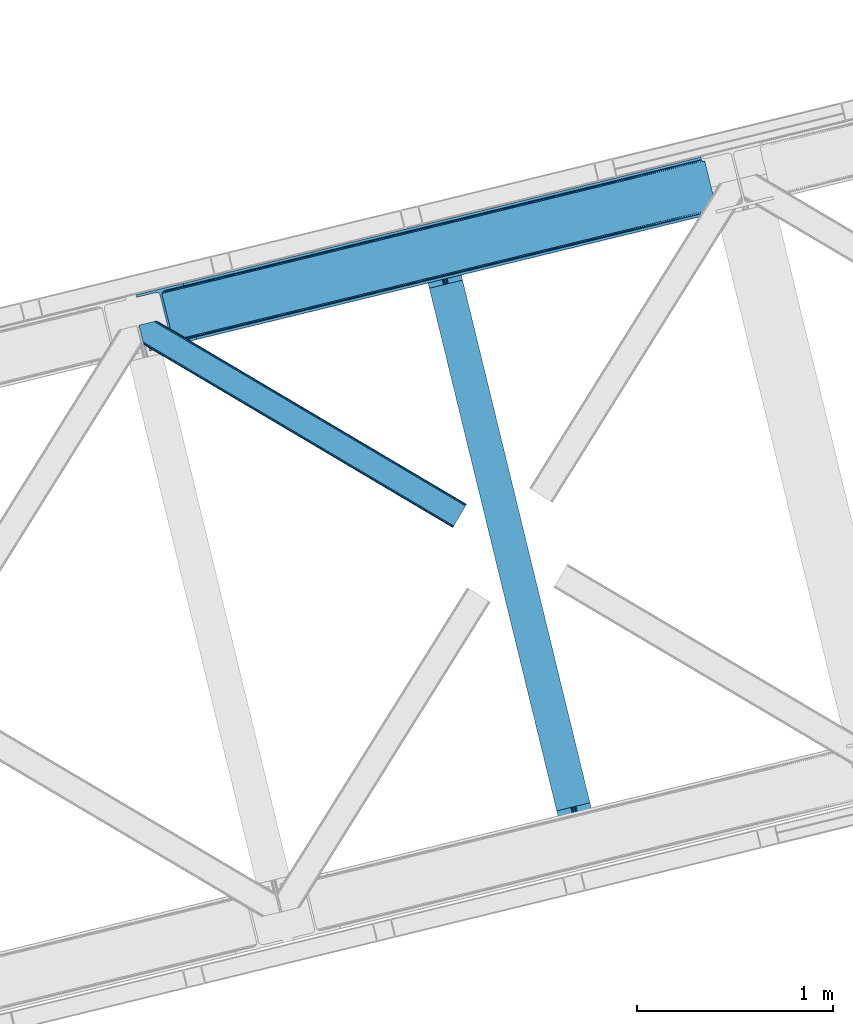
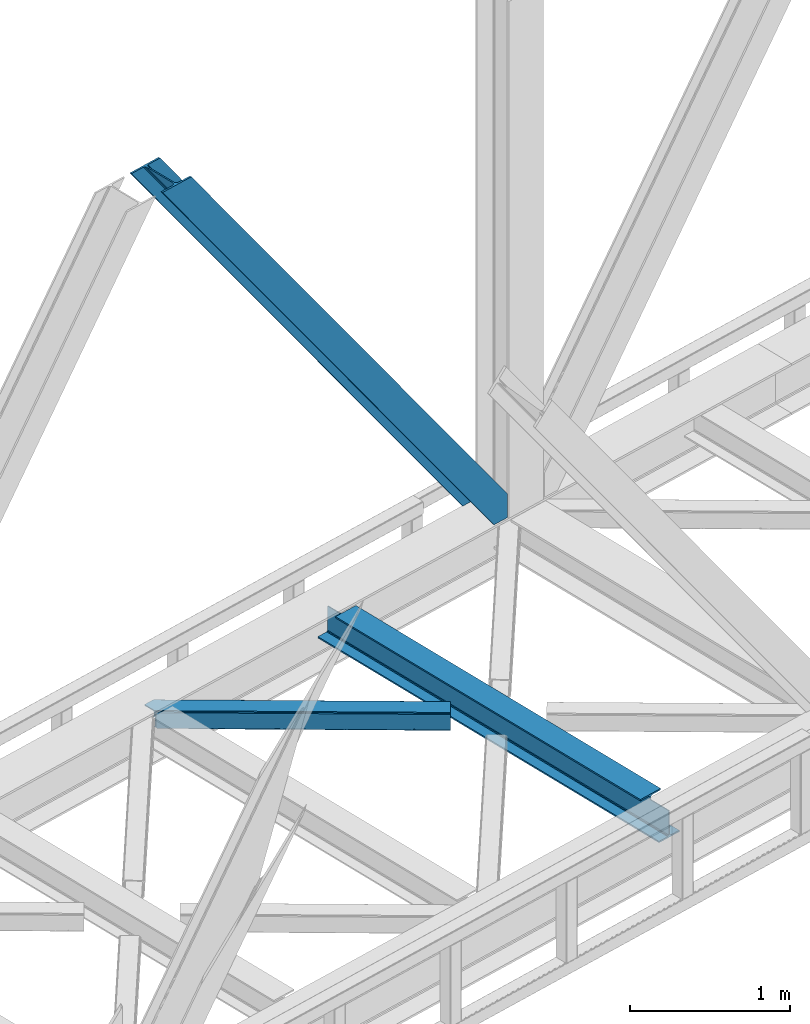
# One storey, part 60 of 93: 2 members, 1 beam.
"""IFC4 building model written with IfcOpenShell, lengths in millimetres."""

from ifc_helpers import new_model, entity, si_unit, converted_unit, derived_unit, direction, frame, origin, place, context, subcontext, project, spatial, triangles, polygons, material, type_object, element, save


model = new_model("IFC4")

# Units and contexts
model_context = context("Model", 3, precision=0.01, world=origin(), true_north=direction((6.12303176911189e-17, 1.0)))
plan_context = context("Plan", 3, precision=0.01, world=origin(), true_north=direction((6.12303176911189e-17, 1.0)))
body_context = subcontext(model_context, "Body", "Model", "MODEL_VIEW")
ifc_project = project(units=[si_unit("LENGTHUNIT", "METRE", prefix="MILLI"), si_unit("AREAUNIT", "SQUARE_METRE"), si_unit("VOLUMEUNIT", "CUBIC_METRE"), converted_unit("PLANEANGLEUNIT", "DEGREE", entity("IfcRatioMeasure", 0.0174532925199433), si_unit("PLANEANGLEUNIT", "RADIAN"), dimensions=[0, 0, 0, 0, 0, 0, 0]), si_unit("MASSUNIT", "GRAM", prefix="KILO"), derived_unit("MASSDENSITYUNIT", [(si_unit("MASSUNIT", "GRAM", prefix="KILO"), 1), (si_unit("LENGTHUNIT", "METRE"), -3)]), derived_unit("MOMENTOFINERTIAUNIT", [(si_unit("LENGTHUNIT", "METRE"), 4)]), si_unit("TIMEUNIT", "SECOND"), si_unit("FREQUENCYUNIT", "HERTZ"), si_unit("THERMODYNAMICTEMPERATUREUNIT", "DEGREE_CELSIUS"), derived_unit("THERMALTRANSMITTANCEUNIT", [(si_unit("MASSUNIT", "GRAM", prefix="KILO"), 1), (si_unit("THERMODYNAMICTEMPERATUREUNIT", "KELVIN"), -1), (si_unit("TIMEUNIT", "SECOND"), -3)]), derived_unit("VOLUMETRICFLOWRATEUNIT", [(si_unit("LENGTHUNIT", "METRE"), 3), (si_unit("TIMEUNIT", "SECOND"), -1)]), derived_unit("MASSFLOWRATEUNIT", [(si_unit("MASSUNIT", "GRAM", prefix="KILO"), 1), (si_unit("TIMEUNIT", "SECOND"), -1)]), derived_unit("ROTATIONALFREQUENCYUNIT", [(si_unit("TIMEUNIT", "SECOND"), -1)]), si_unit("ELECTRICCURRENTUNIT", "AMPERE"), si_unit("ELECTRICVOLTAGEUNIT", "VOLT"), si_unit("POWERUNIT", "WATT"), si_unit("FORCEUNIT", "NEWTON", prefix="KILO"), si_unit("ILLUMINANCEUNIT", "LUX"), si_unit("LUMINOUSFLUXUNIT", "LUMEN"), si_unit("LUMINOUSINTENSITYUNIT", "CANDELA"), derived_unit("USERDEFINED", [(si_unit("MASSUNIT", "GRAM", prefix="KILO"), -1), (si_unit("LENGTHUNIT", "METRE"), -2), (si_unit("TIMEUNIT", "SECOND"), 3), (si_unit("LUMINOUSFLUXUNIT", "LUMEN"), 1)]), derived_unit("LINEARVELOCITYUNIT", [(si_unit("LENGTHUNIT", "METRE"), 1), (si_unit("TIMEUNIT", "SECOND"), -1)]), si_unit("PRESSUREUNIT", "PASCAL"), derived_unit("USERDEFINED", [(si_unit("LENGTHUNIT", "METRE"), -2), (si_unit("MASSUNIT", "GRAM", prefix="KILO"), 1), (si_unit("TIMEUNIT", "SECOND"), -2)]), derived_unit("LINEARFORCEUNIT", [(si_unit("MASSUNIT", "GRAM", prefix="KILO"), 1), (si_unit("LENGTHUNIT", "METRE"), 1), (si_unit("TIMEUNIT", "SECOND"), -2), (si_unit("LENGTHUNIT", "METRE"), -1)]), derived_unit("PLANARFORCEUNIT", [(si_unit("MASSUNIT", "GRAM", prefix="KILO"), 1), (si_unit("LENGTHUNIT", "METRE"), 1), (si_unit("TIMEUNIT", "SECOND"), -2), (si_unit("LENGTHUNIT", "METRE"), -2)])], contexts=[model_context, plan_context])

# Site, building, storey
site_placement = place(None, origin())
site = spatial("IfcSite", under=ifc_project, at=site_placement, CompositionType="ELEMENT")
building_placement = place(site_placement, origin())
building = spatial("IfcBuilding", under=site, at=building_placement, CompositionType="ELEMENT")
storey_placement = place(building_placement, frame((0.0, 0.0, 15900.0)))
storey = spatial("IfcBuildingStorey", under=building, at=storey_placement, CompositionType="ELEMENT", Elevation=15900.0)

# Beam
ifc_material = material(Name="Metal painted (White)")
beam_type = type_object("IfcBeamType", PredefinedType="BEAM")
beam_placement = place(storey_placement, frame((-25639.1508905886, 11536.3709576732, 3441.0)))
element("IfcBeam", 1, at=beam_placement, inside=storey, type_object=beam_type, material=ifc_material, ObjectType="Steel Beam", PredefinedType="BEAM", context=body_context, shape_type="Tessellation", body=[
    polygons([(898.85391135252, 41.4445662733125, 11.000000000004), (898.85391135252, 41.4445662733103, 2.16573425859679e-12), (170.021610174757, 3031.3960252037, 2.16573425859679e-12), (170.021610174757, 3031.3960252037, 11.000000000004), (832.788371398898, 25.3403919499699, 11.000000000004), (103.956070221131, 3015.29185088035, 11.000000000004), (826.839621377601, 23.8903211957417, 12.217927479826), (98.007320199834, 3013.84178012613, 12.217927479826), (821.796514621497, 22.6610105689216, 15.6862915010192), (92.964213443734, 3012.61246949931, 15.6862915010192), (818.426818418321, 21.8396114687162, 20.8770650821657), (89.5945172405625, 3011.7910703991, 20.8770650821657), (817.243538468639, 21.5511744621227, 27.0000000000047), (88.4112372908766, 3011.50263339251, 27.0000000000047), (81.6103728838801, 3009.84485074157, 27.0000000000047), (81.6103728838801, 3009.84485074157, 203.000000000006), (88.4112372908766, 3011.50263339251, 203.000000000006), (0.0, 2989.95145893039, 2.16573425859679e-12), (0.0, 2989.95145893039, 10.9999999999997), (66.0655399536172, 3006.05563325373, 11.000000000004), (72.014289974914, 3007.50570400796, 12.2179274798217), (77.057396731014, 3008.73501463478, 15.6862915010192), (80.4270929341986, 3009.55641373499, 20.8770650821657), (817.243538468639, 21.5511744621227, 203.000000000006), (810.442674061647, 19.8933918111897, 203.000000000006), (810.442674061647, 19.8933918111897, 27.0000000000047), (809.259394111961, 19.6049548046006, 20.8770650821657), (805.889697908777, 18.7835557043887, 15.6862915010192), (800.846591152677, 17.5542450775707, 12.2179274798217), (794.89784113138, 16.1041743233447, 11.000000000004), (728.832301177763, 2.16573425859679e-12, 10.9999999999997), (728.832301177763, 2.16573425859679e-12, 2.16573425859679e-12), (777.543778045845, 184.415062601696, 203.069791966819), (125.888966506592, 2857.75452019163, 203.000000000006), (126.111847295742, 2856.8401777572, 203.617301946336), (126.124761540265, 2856.78719778431, 217.000003693143), (777.398574796912, 185.010597404074, 217.000003676718), (777.39944540481, 185.007025963197, 204.00000679514), (770.833476881408, 182.385463974447, 203.006342981529), (770.610629219861, 183.299815969778, 203.617301946336), (770.597714975342, 183.352795942671, 217.000003693143), (119.323901718691, 2855.1293963229, 217.000003676718), (119.323031110798, 2855.13296776378, 204.00000679514), (119.178731521747, 2855.72494066435, 203.076120467494), (119.088102099599, 2856.09673754069, 203.000000000006), (778.582059520948, 185.298194377516, 223.122939328039), (781.951055929627, 186.122464201395, 228.313710402595), (786.993691333638, 187.353708426701, 231.782072735464), (792.942270204354, 188.804481281383, 232.999999602236), (859.007721069869, 204.909021065317, 232.999999283132), (859.006247733431, 204.91506504219, 243.999994005812), (688.984866829519, 163.4695582453, 243.999994827032), (688.986340165957, 163.463514268429, 233.000000104353), (755.05179103148, 179.568054052363, 232.999999785253), (761.00069615981, 181.017488520586, 231.782072861012), (766.044260666937, 182.244921343719, 228.313710479427), (769.414647576681, 183.06348700115, 223.12293937232), (118.140416994651, 2854.84179934946, 223.122939328039), (114.771420585976, 2854.01752952557, 228.313710402599), (109.728785181961, 2852.78628530027, 231.782072735464), (103.780206311245, 2851.33551244559, 232.999999602236), (37.7147554457299, 2835.23097266165, 232.999999283128), (37.7162287821674, 2835.22492868478, 243.999994005812), (207.73760968608, 2876.67043548167, 243.999994827032), (207.736136349642, 2876.67647945855, 233.000000104357), (141.670685484119, 2860.57193967461, 232.999999785253), (135.721780355789, 2859.12250520638, 231.782072861012), (130.678215848667, 2857.89507238325, 228.313710479427), (127.307828938918, 2857.07650672582, 223.12293937232)], [[[1, 2, 3, 4]], [[5, 1, 4, 6]], [[7, 5, 6, 8]], [[9, 7, 8, 10]], [[11, 9, 10, 12]], [[13, 11, 12, 14]], [[15, 16, 17, 14, 12, 10, 8, 6, 4, 3, 18, 19, 20, 21, 22, 23]], [[13, 24, 25, 26, 27, 28, 29, 30, 31, 32, 2, 1, 5, 7, 9, 11]], [[2, 32, 18, 3]], [[32, 31, 19, 18]], [[31, 30, 20, 19]], [[27, 26, 15, 23]], [[28, 27, 23, 22]], [[29, 28, 22, 21]], [[30, 29, 21, 20]], [[33, 24, 13, 14, 17, 34, 35, 36, 37, 38]], [[25, 39, 40, 41, 42, 43, 44, 16, 15, 26]], [[39, 25, 24, 33]], [[45, 34, 17, 16]], [[41, 40, 38, 37, 46, 47, 48, 49, 50, 51, 52, 53, 54, 55, 56, 57]], [[42, 58, 59, 60, 61, 62, 63, 64, 65, 66, 67, 68, 69, 36, 35, 43]], [[46, 37, 36, 69]], [[47, 46, 69, 68]], [[48, 47, 68, 67]], [[49, 48, 67, 66]], [[50, 49, 66, 65]], [[51, 50, 65, 64]], [[52, 51, 64, 63]], [[53, 52, 63, 62]], [[54, 53, 62, 61]], [[55, 54, 61, 60]], [[56, 55, 60, 59]], [[57, 56, 59, 58]], [[41, 57, 58, 42]]], closed=False),
])

# Members
member_type_1 = type_object("IfcMemberType", PredefinedType="BRACE")
member_1_placement = place(storey_placement, frame((-27100.5295349121, 14051.5178924561, 3694.99929199219)))
element("IfcMember", 2, at=member_1_placement, inside=storey, type_object=member_type_1, ObjectType="Steel Vertical Brace", PredefinedType="BRACE", context=body_context, shape_type="Tessellation", body=[
    triangles([(2966.89332275391, 730.999566650391, 0.80925292968459), (2967.55142211914, 730.015905761718, 1.10690917968532), (2966.08174438477, 729.657788085939, 0.0), (2964.18651123047, 737.429406738282, 0.0), (2962.43545532227, 728.768307495118, 8.31577148437282), (2962.43545532227, 728.768307495118, 0.0), (2505.85634765625, 612.606793212892, 658.855133056641), (2511.3606628418, 609.931375122071, 662.301434326171), (2954.04294433594, 717.839904785156, 38.6743835449197), (2954.17084350586, 719.764205932617, 32.1678039550752), (2501.41243286133, 617.533236694337, 656.552947998047), (2958.54266967774, 726.957952880859, 14.8293273925774), (2955.07311401367, 722.241961669923, 26.1867736816384), (2955.64052124024, 723.796517944336, 22.4381652832017), (655.166986083987, 156.054428100586, 3289.34108276367), (649.437103271484, 156.068380737304, 3285.27854003906), (213.879968261721, 48.4865753173835, 3911.00081176758), (205.268865966798, 47.7982452392571, 3911.00081176758), (643.935113525393, 158.743798828125, 3281.83223876953), (197.318188476565, 49.8760253906257, 3911.00081176758), (639.491198730469, 163.67024230957, 3279.53005371094), (191.241815185549, 54.4048187255867, 3911.00081176758), (636.784387207033, 170.100082397461, 3278.7231262207), (187.960620117188, 60.6951324462898, 3911.00081176758), (2954.16154174805, 716.45859375, 50.6410949707024), (2517.08822021485, 609.918585205078, 666.36397705078), (2051.60965576172, 496.452255249023, 1322.10767211914), (2045.87977294922, 496.466207885742, 1318.04512939453), (1586.12876586914, 382.987088012695, 1977.85369262695), (1580.39888305664, 382.999877929688, 1973.78882446289), (1120.64787597656, 269.52075805664, 2633.59738769531), (1114.91799316406, 269.534710693359, 2629.53251953125), (2040.37545776367, 499.140463256836, 1314.598828125), (1574.89689331055, 385.675296020509, 1970.34484863281), (1109.41600341797, 272.208966064452, 2626.08854370117), (2035.93154296875, 504.068069458008, 1312.29896850586), (1570.45065307617, 390.601739501953, 1968.04266357422), (1104.9697631836, 277.136572265625, 2623.78635864258), (2498.70562133789, 623.964239501953, 655.74602050781), (2033.22473144531, 510.497909545898, 1311.48971557617), (1567.74384155274, 397.03274230957, 1967.23341064453), (1102.26527709961, 283.566412353515, 2622.97710571289), (2909.00615844727, 963.801635742188, 0.0), (2443.52526855469, 850.335305786133, 655.74602050781), (1978.04437866211, 736.870138549804, 1311.48971557617), (1512.56348876953, 623.40380859375, 1967.23341064453), (1047.08259887695, 509.937478637696, 2622.97710571289), (581.604034423828, 396.472311401367, 3278.7231262207), (132.780267333987, 287.067361450196, 3911.00081176758), (307.43239746094, 71.2909973144524, 3911.00081176758), (2954.16154174805, 716.45859375, 182.433050537107), (2954.35222778321, 715.476095581054, 0.0), (2954.17084350586, 719.764205932617, 0.0), (2954.35222778321, 715.476095581054, 182.495837402341), (2955.64052124024, 723.796517944336, 0.0), (2958.54266967774, 726.957952880859, 0.0), (2957.19624023438, 703.817504882813, 182.495837402341), (310.511279296876, 58.6603729248054, 3911.00081176758), (2957.19624023438, 703.817504882813, 0.0), (2846.09139404297, 676.735437011719, 0.0), (69.8655029296897, 0.0, 3911.00081176758), (2843.01251220703, 689.364898681641, 0.0), (66.78662109375, 12.6306243896488, 3911.00081176758), (160.336724853518, 35.4350463867195, 3911.00081176758), (2936.56494140625, 712.169320678711, 0.0), (2953.95922851563, 734.936535644532, 0.0), (2953.940625, 727.842782592774, 0.0), (177.733337402344, 58.2022613525387, 3911.00081176758), (177.714733886722, 51.1073455810547, 3911.00081176758), (2950.62919921875, 721.024594116212, 0.0), (174.403308105469, 44.2903198242184, 3911.00081176758), (2944.52724609375, 715.520278930664, 0.0), (168.301354980471, 38.7860046386722, 3911.00081176758), (2898.77887573242, 961.307601928711, 0.0), (122.552984619142, 284.573327636719, 3911.00081176758), (2872.85720214844, 973.517321777344, 0.0), (2881.46830444336, 974.205651855469, 0.0), (105.244738769532, 297.471377563477, 3911.00081176758), (96.6289855957039, 296.781884765625, 3911.00081176758), (2889.4189819336, 972.127871704102, 0.0), (113.193090820314, 295.393597412109, 3911.00081176758), (2895.49768066406, 967.599078369141, 0.0), (119.271789550781, 290.864804077148, 3911.00081176758), (3.07888183593968, 273.978625488282, 3911.00081176758), (2779.30477294922, 950.712899780274, 0.0), (2776.22589111328, 963.342361450195, 0.0), (0.0, 286.608087158203, 3911.00081176758), (142.212249755859, 306.482455444337, 3911.00081176758), (150.174554443362, 309.834576416015, 3911.00081176758), (136.110296630861, 300.979302978516, 3911.00081176758), (132.798870849612, 294.161114501952, 3911.00081176758), (240.648101806641, 345.268460083007, 3911.00081176758), (243.72698364258, 332.638998413086, 3911.00081176758), (2887.33073730469, 990.425592041016, 182.495837402341), (2887.33073730469, 990.425592041016, 0.0), (2890.45612792969, 977.806594848633, 182.433050537107), (2890.17242431641, 978.767001342774, 182.495837402341), (1522.42102661133, 644.333926391602, 1977.85369262695), (591.461572265627, 417.402429199219, 3289.34108276367), (1056.9424621582, 530.867596435546, 2633.59738769531), (1987.90191650391, 757.800256347657, 1322.10767211914), (2453.38280639649, 871.265423583985, 666.36397705078), (2890.45612792969, 977.806594848633, 50.6410949707024), (2890.17242431641, 978.767001342774, 0.0), (2890.986328125, 976.525277709961, 38.6743835449197), (2892.14672241211, 974.999789428712, 33.1630920410134), (2891.98394165039, 974.87537841797, 0.0), (2893.56524047852, 973.138275146484, 26.4425720214822), (2895.14421386719, 971.973229980469, 22.4381652832017), (2903.46463623047, 970.684936523438, 8.31577148437282), (2903.46463623047, 970.684936523438, 0.0), (2899.17652587891, 970.50122680664, 0.0), (2899.17652587891, 970.50122680664, 14.8293273925774), (2895.14421386719, 971.973229980469, 0.0), (2907.11092529297, 971.573254394532, 0.0), (2444.64845581055, 863.710070800782, 658.855133056641), (2442.96948852539, 857.29069519043, 656.552947998047), (2908.45037841797, 970.755862426759, 0.80925292968459), (2908.5829284668, 971.932534790039, 1.10690917968532), (581.048254394533, 403.426538085938, 3279.53005371094), (582.724896240237, 409.847076416016, 3281.83223876953), (586.380487060549, 414.753753662109, 3285.27854003906), (2448.30404663086, 868.616748046876, 662.301434326171), (1977.48859863282, 743.824365234375, 1312.29896850586), (1512.00770874024, 630.358035278321, 1968.04266357422), (1046.52681884766, 516.892868041992, 2623.78635864258), (1979.16756591797, 750.243740844728, 1314.598828125), (1513.68667602539, 636.778573608399, 1970.34484863281), (1048.20578613281, 523.312243652344, 2626.08854370117), (1982.82315673828, 755.151580810547, 1318.04512939453), (1517.34226684571, 641.685250854493, 1973.78882446289), (1051.86137695313, 528.218920898438, 2629.53251953125)], [[1, 2, 3], [3, 4, 1], [2, 5, 6], [6, 3, 2], [7, 8, 9], [9, 10, 7], [11, 12, 5], [5, 1, 11], [11, 7, 13], [13, 14, 11], [14, 12, 11], [15, 16, 17], [18, 17, 16], [16, 19, 18], [20, 18, 19], [19, 21, 20], [22, 20, 21], [21, 23, 22], [24, 22, 23], [5, 2, 1], [10, 13, 7], [25, 9, 8], [8, 26, 25], [26, 8, 27], [28, 27, 8], [27, 28, 29], [30, 29, 28], [29, 30, 31], [32, 31, 30], [31, 32, 15], [16, 15, 32], [8, 7, 33], [33, 28, 8], [28, 33, 34], [34, 30, 28], [30, 34, 35], [35, 32, 30], [32, 35, 16], [19, 16, 35], [7, 11, 36], [36, 33, 7], [33, 36, 37], [37, 34, 33], [34, 37, 38], [38, 35, 34], [35, 38, 21], [21, 19, 35], [1, 4, 11], [39, 11, 4], [11, 39, 36], [40, 36, 39], [36, 40, 37], [41, 37, 40], [37, 41, 42], [42, 38, 37], [38, 42, 23], [23, 21, 38], [4, 43, 44], [45, 39, 44], [41, 40, 45], [41, 45, 46], [44, 39, 4], [45, 40, 39], [42, 41, 46], [46, 47, 42], [47, 48, 23], [49, 24, 48], [47, 23, 42], [48, 24, 23], [50, 51, 29], [29, 31, 50], [31, 15, 50], [17, 50, 15], [27, 29, 51], [51, 25, 26], [26, 27, 51], [52, 9, 25], [52, 53, 10], [10, 9, 52], [25, 51, 54], [54, 52, 25], [14, 53, 55], [53, 14, 13], [10, 53, 13], [56, 12, 55], [14, 55, 12], [6, 5, 56], [12, 56, 5], [57, 54, 58], [54, 51, 50], [50, 58, 54], [57, 59, 52], [52, 54, 57], [58, 60, 57], [58, 61, 60], [60, 59, 57], [62, 60, 63], [61, 63, 60], [63, 64, 62], [65, 62, 64], [66, 67, 68], [69, 68, 67], [67, 70, 69], [71, 69, 70], [70, 72, 71], [73, 71, 72], [72, 65, 73], [64, 73, 65], [74, 66, 75], [68, 75, 66], [76, 77, 78], [78, 79, 76], [77, 80, 81], [81, 78, 77], [80, 82, 83], [83, 81, 80], [82, 74, 75], [75, 83, 82], [79, 84, 85], [85, 76, 79], [86, 85, 87], [84, 87, 85], [75, 68, 49], [71, 73, 18], [64, 61, 17], [63, 61, 64], [73, 64, 17], [68, 69, 22], [69, 71, 20], [81, 88, 78], [87, 79, 89], [79, 78, 89], [87, 84, 79], [81, 83, 90], [83, 75, 91], [49, 68, 24], [17, 18, 73], [22, 69, 20], [18, 20, 71], [22, 24, 68], [58, 17, 61], [58, 50, 17], [89, 78, 88], [90, 83, 91], [49, 91, 75], [90, 88, 81], [89, 92, 87], [92, 89, 93], [92, 86, 87], [86, 92, 94], [95, 86, 94], [96, 97, 93], [97, 94, 92], [92, 93, 97], [98, 96, 93], [93, 99, 100], [99, 93, 89], [100, 98, 93], [96, 98, 101], [101, 102, 96], [103, 96, 102], [97, 104, 94], [95, 94, 104], [104, 105, 106], [96, 103, 97], [104, 97, 103], [103, 105, 104], [107, 108, 109], [107, 106, 108], [110, 111, 112], [112, 113, 110], [113, 112, 114], [114, 109, 113], [109, 114, 107], [106, 107, 104], [53, 70, 55], [76, 86, 95], [85, 86, 76], [77, 76, 95], [104, 80, 77], [77, 95, 104], [104, 107, 80], [60, 65, 59], [52, 72, 70], [65, 72, 59], [60, 62, 65], [70, 53, 52], [52, 59, 72], [43, 66, 74], [82, 112, 74], [80, 114, 82], [80, 107, 114], [82, 114, 112], [111, 43, 74], [112, 111, 74], [43, 111, 115], [4, 66, 43], [56, 66, 6], [55, 70, 67], [67, 66, 56], [56, 55, 67], [4, 6, 66], [3, 6, 4], [116, 113, 109], [117, 118, 113], [113, 116, 117], [109, 108, 116], [118, 119, 110], [110, 113, 118], [48, 120, 91], [91, 49, 48], [120, 121, 90], [90, 91, 120], [121, 122, 88], [88, 90, 121], [122, 99, 89], [89, 88, 122], [105, 103, 123], [102, 123, 103], [106, 116, 108], [116, 106, 105], [123, 116, 105], [43, 118, 117], [117, 44, 43], [44, 117, 124], [124, 45, 44], [45, 124, 125], [125, 46, 45], [46, 125, 47], [126, 47, 125], [47, 126, 48], [120, 48, 126], [117, 116, 124], [127, 124, 116], [124, 127, 125], [128, 125, 127], [125, 128, 126], [129, 126, 128], [126, 129, 120], [121, 120, 129], [116, 123, 127], [130, 127, 123], [127, 130, 128], [131, 128, 130], [128, 131, 129], [132, 129, 131], [129, 132, 122], [122, 121, 129], [123, 102, 101], [101, 130, 123], [130, 101, 98], [98, 131, 130], [131, 98, 100], [100, 132, 131], [132, 100, 99], [99, 122, 132], [110, 119, 111], [115, 111, 119], [119, 118, 115], [43, 115, 118]]),
])
member_type_2 = type_object("IfcMemberType", PredefinedType="BRACE")
member_2_placement = place(storey_placement, frame((-27085.4955688477, 13147.4358673096, 3510.00011901855)))
element("IfcMember", 3, at=member_2_placement, inside=storey, type_object=member_type_2, ObjectType="Steel Horizontal Brace", PredefinedType="BRACE", context=body_context, shape_type="Tessellation", body=[
    triangles([(1674.92102050781, 120.470553588868, 122.500662231447), (1674.92102050781, 120.470553588868, 17.5000946044929), (91.5037170410178, 1057.89356689453, 17.5000946044929), (91.5037170410178, 1057.89356689453, 122.500662231447), (1666.00528564453, 105.412170410156, 139.999594116212), (1669.41670532227, 111.174609375001, 138.667117309571), (76.4813781738303, 1054.23099975586, 138.667117309571), (67.1679931640647, 1051.96137084961, 139.999594116212), (1672.30955200196, 116.060357666016, 134.874325561526), (84.3762451171897, 1056.15530090332, 134.874325561526), (1674.2419921875, 119.324111938477, 129.197927856447), (89.6503417968779, 1057.4412689209, 129.197927856447), (18.7686218261733, 958.59497680664, 139.999594116212), (1612.51552734375, 15.0595458984371, 139.999594116212), (0.0, 1035.58795166016, 139.999594116212), (1603.59746704102, 0.0, 122.500662231447), (1604.27882080078, 1.14644165039135, 129.197927856447), (24.5612915039092, 934.827822875977, 122.500662231447), (24.1194580078154, 936.637014770507, 129.197927856447), (1606.21126098633, 4.41135864257922, 134.874325561526), (22.8637207031279, 941.789025878907, 134.874325561526), (1609.10178222656, 9.29594421386719, 138.667117309571), (20.9847656250022, 949.499020385743, 138.667117309571), (1603.59746704102, 0.0, 17.5000946044929), (24.5612915039092, 934.827822875977, 17.5000946044929), (1674.2419921875, 119.324111938477, 10.8028289794929), (89.5619750976584, 1057.42033996582, 10.8167816162131), (162.736578369142, 1014.02182617187, 10.5005218505867), (1672.30955200196, 116.060357666016, 5.12526855468968), (165.152709960938, 1008.33263854981, 5.12526855468968), (164.09696044922, 1012.66493225098, 9.50058288574292), (163.771398925783, 1012.99281921387, 9.74126586914281), (163.417932128908, 1013.34279785156, 10.0005523681648), (163.066790771485, 1013.69393920898, 10.2586761474631), (89.4712829589844, 1057.39708557129, 10.5005218505867), (1669.41670532227, 111.174609375001, 1.33247680664135), (167.031665039063, 1000.62264404297, 1.33247680664135), (1666.00528564453, 105.412170410156, 0.0), (169.250134277347, 991.52668762207, 0.0), (1612.51552734375, 15.0595458984371, 0.0), (204.010803222656, 848.92608947754, 0.0), (166.88748779297, 996.992633056641, 10.5005218505867), (72.035137939456, 1053.1473449707, 10.5005218505867), (168.582733154297, 994.261404418945, 9.50058288574292), (168.166479492189, 994.934619140626, 9.74591674804833), (167.736273193361, 995.627600097656, 10.0005523681648), (167.306066894533, 996.319418334961, 10.2540252685576), (1668.74465332031, 110.036306762695, 12.1260040283232), (1670.67476806641, 113.301223754883, 17.8035644531265), (79.9183776855498, 1055.06932067871, 17.8035644531265), (1665.85180664063, 105.151721191407, 8.3320495605476), (169.398962402345, 990.918585205078, 8.81690368652562), (74.1164062500029, 1053.65429077148, 12.4271484375022), (171.566271972657, 982.020291137696, 6.99957275390625), (1662.43806152344, 99.388119506837, 6.99957275390625), (1671.35612182617, 114.447665405274, 24.4996673583992), (81.7694274902351, 1055.52045593262, 24.4996673583992), (1671.35612182617, 114.447665405274, 115.501089477541), (81.7694274902351, 1055.52045593262, 115.501089477541), (74.641955566407, 1053.78335266113, 127.87475280762), (66.7494140625022, 1051.85905151367, 131.667544555665), (79.9183776855498, 1055.06932067871, 122.196029663086), (57.4360290527366, 1049.5882598877, 133.000021362306), (0.0, 1035.58795166016, 133.000021362306), (1670.67476806641, 113.301223754883, 122.196029663086), (1668.74465332031, 110.036306762695, 127.87475280762), (1665.85180664063, 105.151721191407, 131.667544555665), (1662.43806152344, 99.388119506837, 133.000021362306), (16.4501586914084, 968.101373291016, 133.000021362306), (1616.08042602539, 21.0824340820309, 133.000021362306), (1616.08042602539, 21.0824340820309, 6.99957275390625), (201.692340087891, 858.433648681641, 6.99957275390625), (1609.77615966797, 10.434246826173, 127.87475280762), (1612.66900634766, 15.3199951171882, 131.667544555665), (1607.16469116211, 6.02405090332104, 115.501089477541), (1607.84371948242, 7.1693298339851, 122.196029663086), (1609.10178222656, 9.29594421386719, 1.33247680664135), (1609.77615966797, 10.434246826173, 12.1260040283232), (1606.21126098633, 4.41135864257922, 5.12526855468968), (1612.66900634766, 15.3199951171882, 8.3320495605476), (1604.27882080078, 1.14644165039135, 10.8028289794929), (1607.16469116211, 6.02405090332104, 24.4996673583992), (1607.84371948242, 7.1693298339851, 17.8035644531265), (18.6686279296882, 959.006579589844, 131.667544555665), (20.547583007814, 951.295422363282, 127.87475280762), (21.8033203125015, 946.143411254883, 122.196029663086), (22.2451538085952, 944.334219360351, 115.501089477541), (22.2451538085952, 944.334219360351, 24.4996673583992), (21.7823913574248, 946.229452514648, 17.8163543701194), (21.7614624023445, 946.318981933595, 17.5000946044929), (203.861975097658, 849.534191894532, 8.81690368652562), (206.226947021485, 839.831295776368, 1.33247680664135), (204.675878906251, 846.191372680665, 9.50058288574292), (208.105902099611, 832.121301269532, 5.12526855468968), (209.161651611328, 827.789007568359, 9.50058288574292), (204.685180664063, 844.928659057618, 10.2075164794951), (204.324737548828, 844.906567382814, 10.3540191650391), (203.966619873048, 844.885638427735, 10.5005218505867), (27.014630126956, 947.468911743164, 12.1260040283232), (28.3494323730483, 948.857199096679, 10.5005218505867), (204.680529785157, 845.560015869141, 9.85404968261719), (32.1375732421875, 931.964044189453, 10.8179443359404), (209.136071777346, 827.584368896485, 9.88311767578125), (208.117529296876, 827.8564453125, 10.5005218505867), (208.803533935548, 827.672735595703, 10.0842681884787), (32.5003417968765, 931.828005981446, 10.5005218505867)], [[1, 2, 3], [3, 4, 1], [5, 6, 7], [7, 8, 5], [6, 9, 10], [10, 7, 6], [9, 11, 12], [12, 10, 9], [11, 1, 4], [4, 12, 11], [5, 13, 14], [13, 5, 8], [15, 13, 8], [16, 17, 18], [19, 18, 17], [17, 20, 19], [21, 19, 20], [20, 22, 21], [23, 21, 22], [22, 14, 23], [13, 23, 14], [24, 16, 18], [18, 25, 24], [26, 27, 3], [27, 26, 28], [26, 29, 30], [30, 31, 26], [26, 32, 33], [32, 26, 31], [26, 34, 28], [34, 26, 33], [28, 35, 27], [29, 36, 37], [37, 30, 29], [36, 38, 39], [39, 37, 36], [3, 2, 26], [38, 40, 41], [41, 39, 38], [28, 42, 35], [43, 35, 42], [31, 44, 45], [45, 32, 31], [32, 45, 46], [46, 33, 32], [33, 46, 47], [47, 34, 33], [34, 47, 42], [42, 28, 34], [48, 49, 50], [45, 51, 46], [45, 44, 51], [42, 47, 51], [47, 46, 51], [44, 52, 51], [48, 53, 42], [42, 51, 48], [53, 43, 42], [51, 52, 54], [54, 55, 51], [50, 53, 48], [49, 56, 57], [57, 50, 49], [56, 58, 57], [59, 57, 58], [60, 61, 7], [10, 60, 7], [10, 12, 62], [60, 10, 62], [62, 12, 4], [61, 8, 7], [15, 63, 64], [15, 8, 63], [61, 63, 8], [62, 4, 59], [57, 3, 50], [4, 57, 59], [3, 27, 50], [4, 3, 57], [35, 50, 27], [35, 53, 50], [35, 43, 53], [58, 65, 59], [62, 59, 65], [65, 66, 62], [60, 62, 66], [66, 67, 60], [61, 60, 67], [67, 68, 61], [63, 61, 68], [68, 69, 63], [68, 70, 69], [69, 64, 63], [71, 55, 72], [54, 72, 55], [11, 66, 65], [58, 2, 1], [11, 65, 1], [11, 9, 66], [65, 58, 1], [66, 9, 6], [68, 5, 14], [5, 67, 6], [67, 5, 68], [67, 66, 6], [26, 48, 29], [56, 2, 58], [2, 49, 26], [49, 2, 56], [26, 49, 48], [38, 55, 40], [36, 29, 48], [48, 51, 36], [51, 55, 38], [38, 36, 51], [73, 22, 20], [14, 70, 68], [14, 74, 70], [74, 14, 22], [73, 74, 22], [75, 16, 24], [17, 76, 73], [20, 17, 73], [76, 17, 16], [75, 76, 16], [77, 78, 79], [40, 55, 71], [71, 80, 40], [80, 78, 77], [77, 40, 80], [81, 79, 78], [24, 82, 75], [83, 24, 81], [24, 83, 82], [83, 81, 78], [70, 74, 84], [84, 69, 70], [74, 73, 85], [85, 84, 74], [73, 76, 86], [86, 85, 73], [76, 75, 87], [87, 86, 76], [75, 82, 88], [88, 87, 75], [86, 87, 18], [18, 19, 86], [21, 86, 19], [86, 21, 85], [18, 88, 25], [89, 90, 25], [25, 88, 89], [87, 88, 18], [84, 23, 13], [15, 69, 13], [64, 69, 15], [84, 85, 23], [23, 85, 21], [69, 84, 13], [44, 30, 37], [39, 44, 37], [54, 52, 39], [54, 39, 72], [30, 44, 31], [39, 52, 44], [72, 41, 91], [41, 92, 93], [41, 72, 39], [94, 93, 92], [41, 93, 91], [94, 95, 93], [83, 89, 88], [71, 72, 91], [78, 96, 97], [97, 98, 78], [98, 99, 78], [98, 100, 99], [80, 91, 93], [93, 78, 80], [78, 93, 101], [101, 96, 78], [83, 78, 99], [99, 90, 83], [90, 89, 83], [91, 80, 71], [88, 82, 83], [24, 25, 102], [79, 103, 95], [81, 102, 104], [104, 79, 81], [104, 105, 79], [95, 94, 79], [40, 77, 92], [92, 41, 40], [77, 79, 94], [94, 92, 77], [106, 81, 24], [99, 106, 25], [99, 100, 106], [25, 90, 99], [98, 104, 106], [106, 100, 98]]),
])

save(model, "model.ifc")
